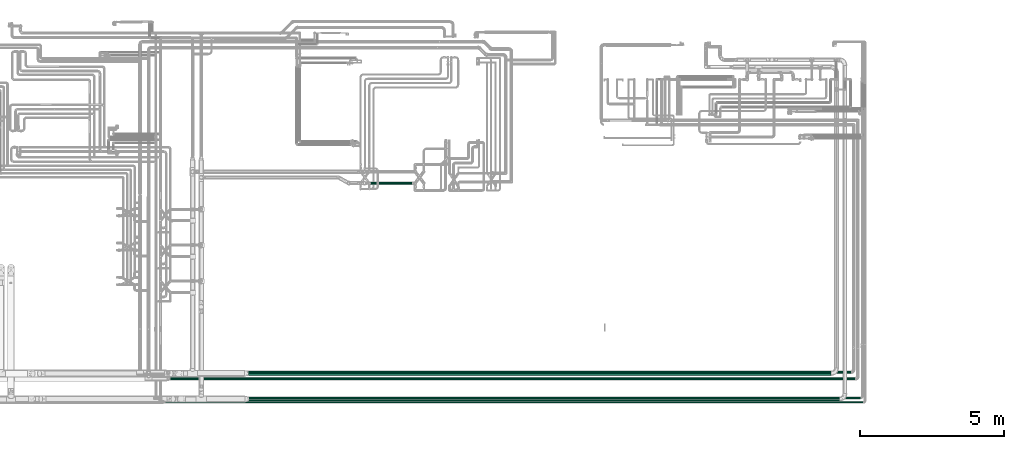
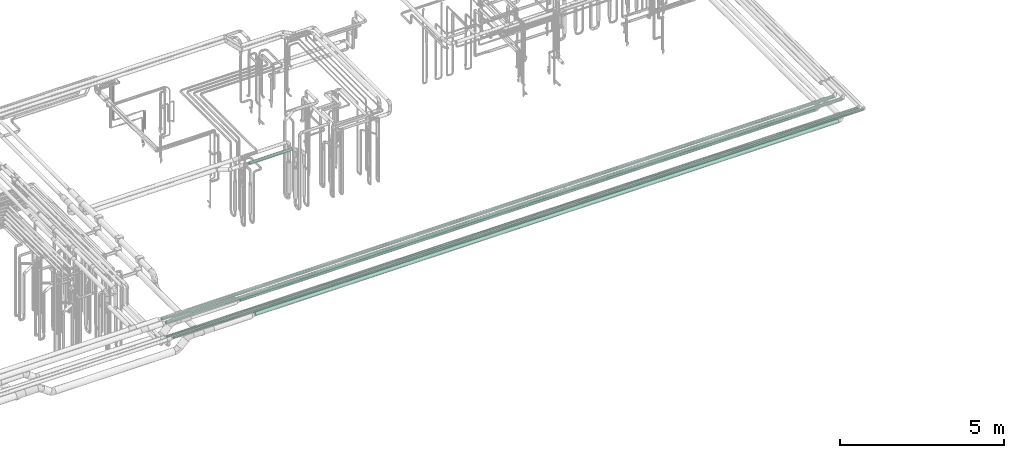
# One storey, part 539 of 827: 7 flow segments.
"""IFC2X3 building model written with IfcOpenShell, lengths in millimetres."""

import ifcopenshell
import ifcopenshell.guid

model = None  # the IFC model being written
_history = None  # IfcOwnerHistory: only IFC2X3 demands one
_inside = {}  # id of a spatial element -> (the spatial element, [elements in it])
_under = {}  # id of a project, library or spatial element -> (it, [spatial elements below it])
_declared = {}  # id of a project -> (the project, [libraries it declares])
_typed = {}  # id of a type object -> (the type object, [elements of that type])
_made_of = {}  # id of a material, layer set ... -> (it, [elements and type objects made of it])


def new_model(schema):
    """Start an empty IFC model of exactly this schema.

    Asked for "IFC4X3", IfcOpenShell would pick the latest addendum, in which some entities
    have other attributes; the version numbers below select the first issue.
    IFC2X3 requires an IfcOwnerHistory on every rooted entity: one is made here for all.
    """
    global model, _history
    if schema == "IFC4X3":
        model = ifcopenshell.file(schema_version=(4, 3, 0, 0))
    else:
        model = ifcopenshell.file(schema=schema)
    _inside.clear()
    _under.clear()
    _declared.clear()
    _typed.clear()
    _made_of.clear()
    _history = None
    if model.schema == "IFC2X3":
        org = make("IfcOrganization", Name="unknown")
        user = make(
            "IfcPersonAndOrganization",
            ThePerson=make("IfcPerson", FamilyName="unknown"),
            TheOrganization=org,
        )
        app = make(
            "IfcApplication",
            ApplicationDeveloper=org,
            Version="unknown",
            ApplicationFullName="unknown",
            ApplicationIdentifier="unknown",
        )
        _history = make(
            "IfcOwnerHistory",
            OwningUser=user,
            OwningApplication=app,
            ChangeAction="ADDED",
            CreationDate=0,
        )
    return model


def make(cls, **values):
    """One entity of the class cls with the attributes given. An attribute that is None is left unset."""
    return model.create_entity(
        cls, **{name: value for name, value in values.items() if value is not None}
    )


def entity(cls, *values):
    """Any entity or typed value of the class cls, its attributes in the order of the schema. None: left unset."""
    e = model.create_entity(cls)
    for i, value in enumerate(values):
        if value is not None:
            e[i] = value
    return e


def rooted(cls, **values):
    """An entity with a GlobalId (a new one), such as an element, a storey or a relation."""
    return make(cls, GlobalId=ifcopenshell.guid.new(), OwnerHistory=_history, **values)


def si_unit(unit_type, name, prefix=None):
    """IfcSIUnit, for example si_unit("LENGTHUNIT", "METRE", prefix="MILLI")."""
    return make("IfcSIUnit", UnitType=unit_type, Prefix=prefix, Name=name)


def converted_unit(unit_type, name, factor, base, dimensions=None, offset=None):
    """IfcConversionBasedUnit, such as the inch: factor (a typed value) times the base unit."""
    return make(
        "IfcConversionBasedUnit"
        if offset is None
        else "IfcConversionBasedUnitWithOffset",
        ConversionOffset=offset,
        Dimensions=None
        if dimensions is None
        else entity("IfcDimensionalExponents", *dimensions),
        UnitType=unit_type,
        Name=name,
        ConversionFactor=make(
            "IfcMeasureWithUnit", ValueComponent=factor, UnitComponent=base
        ),
    )


def derived_unit(unit_type, elements):
    """IfcDerivedUnit: a product of units, each with its exponent."""
    return make(
        "IfcDerivedUnit",
        Elements=[
            make("IfcDerivedUnitElement", Unit=unit, Exponent=power)
            for unit, power in elements
        ],
        UnitType=unit_type,
    )


def assignment(units):
    """IfcUnitAssignment: the units of a project."""
    return None if units is None else make("IfcUnitAssignment", Units=units)


def point(xyz):
    """IfcCartesianPoint."""
    return None if xyz is None else make("IfcCartesianPoint", Coordinates=xyz)


def direction(xyz):
    """IfcDirection."""
    return None if xyz is None else make("IfcDirection", DirectionRatios=xyz)


def frame(location, z_axis=None, x_axis=None):
    """IfcAxis2Placement3D, a coordinate frame: its origin and axes. An axis left out is left unset."""
    return make(
        "IfcAxis2Placement3D",
        Location=point(location),
        Axis=direction(z_axis),
        RefDirection=direction(x_axis),
    )


def frame_2d(location, x_axis=None):
    """IfcAxis2Placement2D, a coordinate frame in the plane: its origin and x axis."""
    return make(
        "IfcAxis2Placement2D", Location=point(location), RefDirection=direction(x_axis)
    )


def origin():
    """The frame at (0, 0, 0) with its axes left unset."""
    return frame((0.0, 0.0, 0.0))


def origin_2d_with_axis():
    """The frame at (0, 0) in the plane with the x axis (1, 0) written out."""
    return frame_2d((0.0, 0.0), x_axis=(1.0, 0.0))


def place(relative_to, where):
    """IfcLocalPlacement: puts the frame where relative to a parent placement (None: the world)."""
    return make(
        "IfcLocalPlacement", PlacementRelTo=relative_to, RelativePlacement=where
    )


def context(
    kind, dimensions, precision=None, world=None, true_north=None, identifier=None
):
    """IfcGeometricRepresentationContext, for example the 3D "Model" context."""
    return make(
        "IfcGeometricRepresentationContext",
        ContextIdentifier=identifier,
        ContextType=kind,
        CoordinateSpaceDimension=dimensions,
        Precision=precision,
        WorldCoordinateSystem=world,
        TrueNorth=true_north,
    )


def subcontext(parent, identifier, kind, view, scale=None):
    """IfcGeometricRepresentationSubContext, for example "Body" below "Model"."""
    return make(
        "IfcGeometricRepresentationSubContext",
        ContextIdentifier=identifier,
        ContextType=kind,
        ParentContext=parent,
        TargetScale=scale,
        TargetView=view,
    )


def project(units=None, contexts=None):
    """IfcProject with its units and contexts."""
    return rooted(
        "IfcProject",
        Name="project",
        RepresentationContexts=contexts,
        UnitsInContext=assignment(units),
    )


def spatial(cls, under=None, at=None, **own):
    """A site, building, storey or space (cls), placed at a placement, below another one or the project."""
    s = rooted(cls, ObjectPlacement=at, **own)
    if under is not None:
        _under.setdefault(under.id(), (under, []))[1].append(s)
    return s


def profile(cls, at=None, kind="AREA", **sizes):
    """A parametric profile (cls). Its sizes go by their IFC names, for example OverallWidth=200.0."""
    return make(cls, ProfileType=kind, Position=at, **sizes)


def circle(**sizes):
    """IfcCircleProfileDef."""
    return profile("IfcCircleProfileDef", **sizes)


def extrude(swept, where, along, depth):
    """IfcExtrudedAreaSolid: the profile swept, set in the frame where, extruded along a direction by depth."""
    return make(
        "IfcExtrudedAreaSolid",
        SweptArea=swept,
        Position=where,
        ExtrudedDirection=direction(along),
        Depth=depth,
    )


def shape(context_of_items, identifier, shape_type, items):
    """IfcShapeRepresentation: the items that make up one representation, for example the "Body"."""
    return make(
        "IfcShapeRepresentation",
        ContextOfItems=context_of_items,
        RepresentationIdentifier=identifier,
        RepresentationType=shape_type,
        Items=items,
    )


def made_of(thing, what):
    """Note that an element or type object is made of a material, layer set ...; save() writes the relation."""
    if what is not None:
        _made_of.setdefault(what.id(), (what, []))[1].append(thing)
    return thing


def type_object(cls, material=None, **own):
    """A type object (cls), such as IfcWallType, which elements share."""
    return made_of(rooted(cls, **own), material)


def element(
    cls,
    number,
    at=None,
    inside=None,
    cuts=None,
    type_object=None,
    material=None,
    context=None,
    identifier="Body",
    shape_type=None,
    held_by="IfcProductDefinitionShape",
    body=None,
    shapes=None,
    **own,
):
    """One element of the class cls, such as IfcWall. Its Tag is "e" and its number.

    at: its placement. inside: the storey or other place that contains it. cuts: it is an
    opening in that element (IfcRelVoidsElement). A single representation is given by context,
    identifier, shape_type and body (its items); several are given by shapes. held_by: the class
    of the entity that holds the representations. save() writes the other relations.
    """
    e = rooted(cls, Tag="e%d" % number, ObjectPlacement=at, **own)
    if body is not None:
        shapes = [shape(context, identifier, shape_type, body)]
    if shapes is not None:
        e.Representation = make(held_by, Representations=shapes)
    if inside is not None:
        _inside.setdefault(inside.id(), (inside, []))[1].append(e)
    if cuts is not None:
        rooted(
            "IfcRelVoidsElement", RelatingBuildingElement=cuts, RelatedOpeningElement=e
        )
    if type_object is not None:
        _typed.setdefault(type_object.id(), (type_object, []))[1].append(e)
    return made_of(e, material)


def aggregate(whole, parts):
    """IfcRelAggregates: a whole, such as a stair, and the parts it consists of."""
    return rooted("IfcRelAggregates", RelatingObject=whole, RelatedObjects=parts)


def save(model, path):
    """Write the relations noted so far, then the file.

    IfcRelAggregates (storeys below a building ...), IfcRelContainedInSpatialStructure (elements
    in a storey), IfcRelDefinesByType, IfcRelAssociatesMaterial and IfcRelDeclares: one each for
    every whole, place, type object, material and project.
    """
    for whole, parts in _under.values():
        aggregate(whole, parts)
    for where, things in _inside.values():
        rooted(
            "IfcRelContainedInSpatialStructure",
            RelatedElements=things,
            RelatingStructure=where,
        )
    for kind, things in _typed.values():
        rooted("IfcRelDefinesByType", RelatedObjects=things, RelatingType=kind)
    for what, things in _made_of.values():
        rooted("IfcRelAssociatesMaterial", RelatedObjects=things, RelatingMaterial=what)
    for by, libraries in _declared.values():
        rooted("IfcRelDeclares", RelatingContext=by, RelatedDefinitions=libraries)
    model.write(path)


model = new_model("IFC2X3")

# Units and contexts
model_context = context("Model", 3, precision=0.01, world=origin(), true_north=direction((6.12303176911189e-17, 1.0)))
body_context = subcontext(model_context, "Body", "Model", "MODEL_VIEW")
ifc_project = project(units=[si_unit("LENGTHUNIT", "METRE", prefix="MILLI"), si_unit("AREAUNIT", "SQUARE_METRE"), si_unit("VOLUMEUNIT", "CUBIC_METRE"), converted_unit("PLANEANGLEUNIT", "DEGREE", entity("IfcRatioMeasure", 0.0174532925199433), si_unit("PLANEANGLEUNIT", "RADIAN"), dimensions=[0, 0, 0, 0, 0, 0, 0]), si_unit("MASSUNIT", "GRAM", prefix="KILO"), derived_unit("MASSDENSITYUNIT", [(si_unit("MASSUNIT", "GRAM", prefix="KILO"), 1), (si_unit("LENGTHUNIT", "METRE"), -3)]), derived_unit("MOMENTOFINERTIAUNIT", [(si_unit("LENGTHUNIT", "METRE"), 4)]), si_unit("TIMEUNIT", "SECOND"), si_unit("FREQUENCYUNIT", "HERTZ"), si_unit("THERMODYNAMICTEMPERATUREUNIT", "DEGREE_CELSIUS"), derived_unit("THERMALTRANSMITTANCEUNIT", [(si_unit("MASSUNIT", "GRAM", prefix="KILO"), 1), (si_unit("THERMODYNAMICTEMPERATUREUNIT", "KELVIN"), -1), (si_unit("TIMEUNIT", "SECOND"), -3)]), derived_unit("VOLUMETRICFLOWRATEUNIT", [(si_unit("LENGTHUNIT", "METRE"), 3), (si_unit("TIMEUNIT", "SECOND"), -1)]), derived_unit("MASSFLOWRATEUNIT", [(si_unit("MASSUNIT", "GRAM", prefix="KILO"), 1), (si_unit("TIMEUNIT", "SECOND"), -1)]), derived_unit("ROTATIONALFREQUENCYUNIT", [(si_unit("TIMEUNIT", "SECOND"), -1)]), si_unit("ELECTRICCURRENTUNIT", "AMPERE"), si_unit("ELECTRICVOLTAGEUNIT", "VOLT"), si_unit("POWERUNIT", "WATT"), si_unit("FORCEUNIT", "NEWTON", prefix="KILO"), si_unit("ILLUMINANCEUNIT", "LUX"), si_unit("LUMINOUSFLUXUNIT", "LUMEN"), si_unit("LUMINOUSINTENSITYUNIT", "CANDELA"), derived_unit("USERDEFINED", [(si_unit("MASSUNIT", "GRAM", prefix="KILO"), -1), (si_unit("LENGTHUNIT", "METRE"), -2), (si_unit("TIMEUNIT", "SECOND"), 3), (si_unit("LUMINOUSFLUXUNIT", "LUMEN"), 1)]), derived_unit("LINEARVELOCITYUNIT", [(si_unit("LENGTHUNIT", "METRE"), 1), (si_unit("TIMEUNIT", "SECOND"), -1)]), si_unit("PRESSUREUNIT", "PASCAL"), derived_unit("USERDEFINED", [(si_unit("LENGTHUNIT", "METRE"), -2), (si_unit("MASSUNIT", "GRAM", prefix="KILO"), 1), (si_unit("TIMEUNIT", "SECOND"), -2)]), derived_unit("LINEARFORCEUNIT", [(si_unit("MASSUNIT", "GRAM", prefix="KILO"), 1), (si_unit("LENGTHUNIT", "METRE"), 1), (si_unit("TIMEUNIT", "SECOND"), -2), (si_unit("LENGTHUNIT", "METRE"), -1)]), derived_unit("PLANARFORCEUNIT", [(si_unit("MASSUNIT", "GRAM", prefix="KILO"), 1), (si_unit("LENGTHUNIT", "METRE"), 1), (si_unit("TIMEUNIT", "SECOND"), -2), (si_unit("LENGTHUNIT", "METRE"), -2)])], contexts=[model_context])

# Site, building, storey
site_placement = place(None, origin())
site = spatial("IfcSite", under=ifc_project, at=site_placement, CompositionType="ELEMENT")
building_placement = place(site_placement, origin())
building = spatial("IfcBuilding", under=site, at=building_placement, CompositionType="ELEMENT")
storey_placement = place(building_placement, frame((0.0, 0.0, 28200.0)))
storey = spatial("IfcBuildingStorey", under=building, at=storey_placement, Name="08", CompositionType="ELEMENT", Elevation=28200.0)

# Flow segments
pipe_segment_type_1 = type_object("IfcPipeSegmentType", PredefinedType="NOTDEFINED")
flow_segment_1_placement = place(storey_placement, frame((39715.11, 6306.9, 2831.9)))
element("IfcFlowSegment", 1, at=flow_segment_1_placement, inside=storey, type_object=pipe_segment_type_1, context=body_context, shape_type="SweptSolid", body=[
    extrude(circle(Radius=66.5, at=origin_2d_with_axis()), frame((0.0, 68.1, 68.1), z_axis=(1.0, 0.0, 0.0), x_axis=(0.0, 1.0, 0.0)), (0.0, 0.0, 1.0), 20545.9401755387),
])
flow_segment_2_placement = place(storey_placement, frame((39691.04, 7198.11, 2831.78)))
element("IfcFlowSegment", 2, at=flow_segment_2_placement, inside=storey, type_object=pipe_segment_type_1, context=body_context, shape_type="SweptSolid", body=[
    extrude(circle(Radius=66.5, at=origin_2d_with_axis()), frame((0.0, 68.1, 68.1), z_axis=(1.0, 0.0, 4.27481930448548e-06), x_axis=(0.0, 1.0, 0.0)), (0.0, 0.0, 1.0), 20277.5004791467),
])
pipe_segment_type_2 = type_object("IfcPipeSegmentType", PredefinedType="NOTDEFINED")
flow_segment_3_placement = place(storey_placement, frame((36979.83, 7040.65, 3060.65)))
element("IfcFlowSegment", 3, at=flow_segment_3_placement, inside=storey, type_object=pipe_segment_type_2, context=body_context, shape_type="SweptSolid", body=[
    extrude(circle(Radius=37.75, at=origin_2d_with_axis()), frame((0.0, 39.35, 39.35), z_axis=(1.0, 0.0, 0.0), x_axis=(0.0, 1.0, 0.0)), (0.0, 0.0, 1.0), 23828.2704925099),
])
flow_segment_4_placement = place(storey_placement, frame((36962.03, 7270.65, 3060.65)))
element("IfcFlowSegment", 4, at=flow_segment_4_placement, inside=storey, type_object=pipe_segment_type_2, context=body_context, shape_type="SweptSolid", body=[
    extrude(circle(Radius=37.75, at=origin_2d_with_axis()), frame((0.0, 39.35, 39.35), z_axis=(1.0, 0.0, 0.0), x_axis=(0.0, -1.0, 0.0)), (0.0, 0.0, 1.0), 23696.06979),
])
flow_segment_5_placement = place(storey_placement, frame((43856.18, 13844.33, 2454.15)))
element("IfcFlowSegment", 5, at=flow_segment_5_placement, inside=storey, type_object=pipe_segment_type_2, context=body_context, shape_type="SweptSolid", body=[
    extrude(circle(Radius=44.25, at=origin_2d_with_axis()), frame((0.0, 45.85, 45.85), z_axis=(1.0, 0.0, 0.0), x_axis=(0.0, 1.0, 0.0)), (0.0, 0.0, 1.0), 1523.09721919177),
])
flow_segment_6_placement = place(storey_placement, frame((36794.64, 6240.11, 3074.4)))
element("IfcFlowSegment", 6, at=flow_segment_6_placement, inside=storey, type_object=pipe_segment_type_2, context=body_context, shape_type="SweptSolid", body=[
    extrude(circle(Radius=24.0, at=origin_2d_with_axis()), frame((0.0, 25.6, 25.6), z_axis=(1.0, 0.0, 0.0), x_axis=(0.0, 1.0, 0.0)), (0.0, 0.0, 1.0), 24300.9943574319),
])
flow_segment_7_placement = place(storey_placement, frame((36633.72, 6390.97, 3074.4)))
element("IfcFlowSegment", 7, at=flow_segment_7_placement, inside=storey, type_object=pipe_segment_type_2, context=body_context, shape_type="SweptSolid", body=[
    extrude(circle(Radius=24.0, at=origin_2d_with_axis()), frame((0.0, 25.6, 25.6), z_axis=(1.0, 0.0, 0.0), x_axis=(0.0, 1.0, 0.0)), (0.0, 0.0, 1.0), 24361.9213538406),
])

save(model, "model.ifc")
